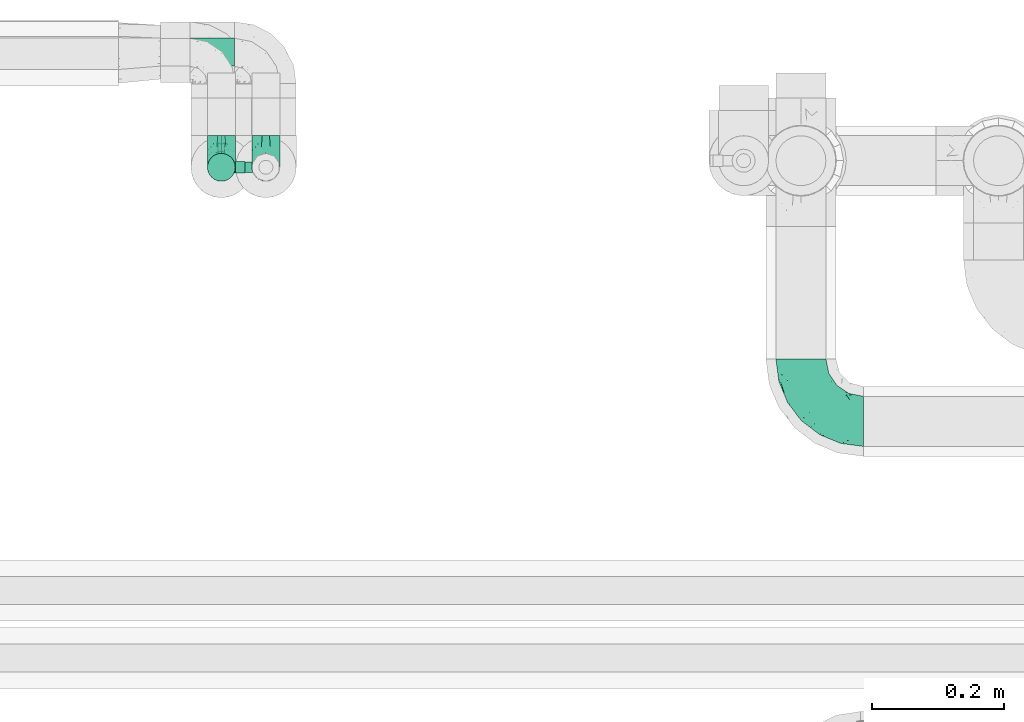
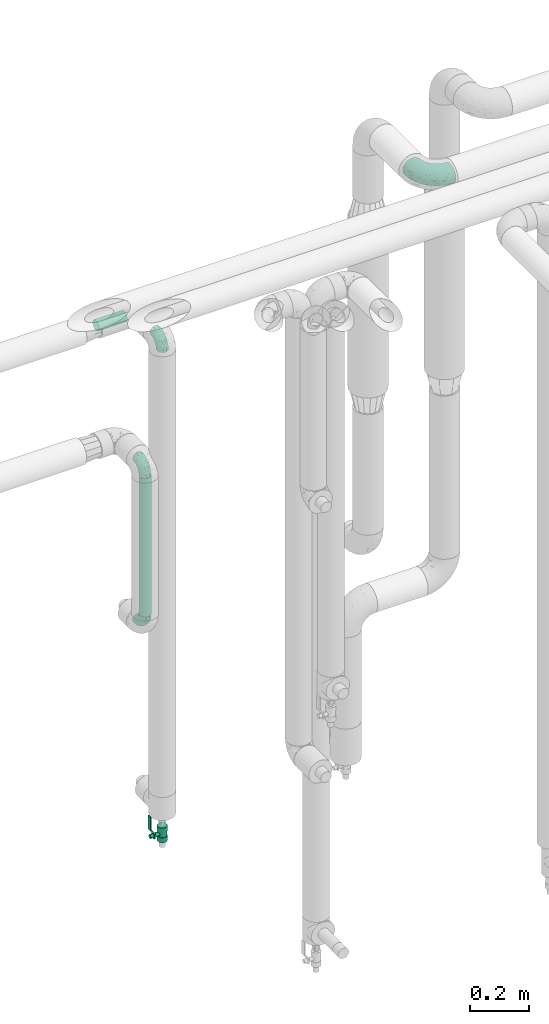
# One storey, part 640 of 827: 4 flow fittings, 2 flow segments, 1 flow controller.
"""IFC2X3 building model written with IfcOpenShell, lengths in millimetres."""

from ifc_helpers import new_model, entity, si_unit, converted_unit, derived_unit, direction, frame, origin, origin_2d_with_axis, place, context, subcontext, project, spatial, polyline, circle, outline, extrude, faceted_brep, source, transform, mapped, material, material_list, type_object, type_shapes, element, save


model = new_model("IFC2X3")

# Units and contexts
model_context = context("Model", 3, precision=0.01, world=origin(), true_north=direction((6.12303176911189e-17, 1.0)))
body_context = subcontext(model_context, "Body", "Model", "MODEL_VIEW")
ifc_project = project(units=[si_unit("LENGTHUNIT", "METRE", prefix="MILLI"), si_unit("AREAUNIT", "SQUARE_METRE"), si_unit("VOLUMEUNIT", "CUBIC_METRE"), converted_unit("PLANEANGLEUNIT", "DEGREE", entity("IfcRatioMeasure", 0.0174532925199433), si_unit("PLANEANGLEUNIT", "RADIAN"), dimensions=[0, 0, 0, 0, 0, 0, 0]), si_unit("MASSUNIT", "GRAM", prefix="KILO"), derived_unit("MASSDENSITYUNIT", [(si_unit("MASSUNIT", "GRAM", prefix="KILO"), 1), (si_unit("LENGTHUNIT", "METRE"), -3)]), derived_unit("MOMENTOFINERTIAUNIT", [(si_unit("LENGTHUNIT", "METRE"), 4)]), si_unit("TIMEUNIT", "SECOND"), si_unit("FREQUENCYUNIT", "HERTZ"), si_unit("THERMODYNAMICTEMPERATUREUNIT", "DEGREE_CELSIUS"), derived_unit("THERMALTRANSMITTANCEUNIT", [(si_unit("MASSUNIT", "GRAM", prefix="KILO"), 1), (si_unit("THERMODYNAMICTEMPERATUREUNIT", "KELVIN"), -1), (si_unit("TIMEUNIT", "SECOND"), -3)]), derived_unit("VOLUMETRICFLOWRATEUNIT", [(si_unit("LENGTHUNIT", "METRE"), 3), (si_unit("TIMEUNIT", "SECOND"), -1)]), derived_unit("MASSFLOWRATEUNIT", [(si_unit("MASSUNIT", "GRAM", prefix="KILO"), 1), (si_unit("TIMEUNIT", "SECOND"), -1)]), derived_unit("ROTATIONALFREQUENCYUNIT", [(si_unit("TIMEUNIT", "SECOND"), -1)]), si_unit("ELECTRICCURRENTUNIT", "AMPERE"), si_unit("ELECTRICVOLTAGEUNIT", "VOLT"), si_unit("POWERUNIT", "WATT"), si_unit("FORCEUNIT", "NEWTON", prefix="KILO"), si_unit("ILLUMINANCEUNIT", "LUX"), si_unit("LUMINOUSFLUXUNIT", "LUMEN"), si_unit("LUMINOUSINTENSITYUNIT", "CANDELA"), derived_unit("USERDEFINED", [(si_unit("MASSUNIT", "GRAM", prefix="KILO"), -1), (si_unit("LENGTHUNIT", "METRE"), -2), (si_unit("TIMEUNIT", "SECOND"), 3), (si_unit("LUMINOUSFLUXUNIT", "LUMEN"), 1)]), derived_unit("LINEARVELOCITYUNIT", [(si_unit("LENGTHUNIT", "METRE"), 1), (si_unit("TIMEUNIT", "SECOND"), -1)]), si_unit("PRESSUREUNIT", "PASCAL"), derived_unit("USERDEFINED", [(si_unit("LENGTHUNIT", "METRE"), -2), (si_unit("MASSUNIT", "GRAM", prefix="KILO"), 1), (si_unit("TIMEUNIT", "SECOND"), -2)]), derived_unit("LINEARFORCEUNIT", [(si_unit("MASSUNIT", "GRAM", prefix="KILO"), 1), (si_unit("LENGTHUNIT", "METRE"), 1), (si_unit("TIMEUNIT", "SECOND"), -2), (si_unit("LENGTHUNIT", "METRE"), -1)]), derived_unit("PLANARFORCEUNIT", [(si_unit("MASSUNIT", "GRAM", prefix="KILO"), 1), (si_unit("LENGTHUNIT", "METRE"), 1), (si_unit("TIMEUNIT", "SECOND"), -2), (si_unit("LENGTHUNIT", "METRE"), -2)])], contexts=[model_context])

# Site, building, storey
site_placement = place(None, origin())
site = spatial("IfcSite", under=ifc_project, at=site_placement, CompositionType="ELEMENT")
building_placement = place(site_placement, origin())
building = spatial("IfcBuilding", under=site, at=building_placement, CompositionType="ELEMENT")
storey_placement = place(building_placement, frame((0.0, 0.0, 28200.0)))
storey = spatial("IfcBuildingStorey", under=building, at=storey_placement, Name="08", CompositionType="ELEMENT", Elevation=28200.0)

# Flow segments
pipe_segment_type = type_object("IfcPipeSegmentType", PredefinedType="NOTDEFINED")
flow_segment_1_placement = place(storey_placement, frame((30551.84, 19320.69, 1178.45)))
element("IfcFlowSegment", 1, at=flow_segment_1_placement, inside=storey, type_object=pipe_segment_type, context=body_context, shape_type="SweptSolid", body=[
    extrude(circle(Radius=21.15, at=origin_2d_with_axis()), frame((22.75, 22.75, 0.0), z_axis=(0.0, 0.0, 1.0), x_axis=(-1.0, 0.0, 0.0)), (0.0, 0.0, 1.0), 573.551740000017),
])
flow_segment_2_placement = place(storey_placement, frame((30482.2, 19495.69, 2277.25)))
element("IfcFlowSegment", 2, at=flow_segment_2_placement, inside=storey, type_object=pipe_segment_type, context=body_context, shape_type="SweptSolid", body=[
    extrude(circle(Radius=21.15, at=origin_2d_with_axis()), frame((0.0, 22.75, 22.75), z_axis=(1.0, 0.0, 0.0), x_axis=(0.0, 1.0, 0.0)), (0.0, 0.0, 1.0), 112.000000000009),
])

# Flow controller
ifc_material = material()
ifc_material_list = material_list([ifc_material, ifc_material, ifc_material, ifc_material, ifc_material])
valve_type = type_object("IfcValveType", PredefinedType="NOTDEFINED", material=ifc_material_list)
shared_shape_1 = source(origin(), body_context, "Body", "SweptSolid", [
    extrude(circle(Radius=17.5, at=origin_2d_with_axis()), frame((-30.5, 0.0, 0.0), z_axis=(1.0, 0.0, 0.0), x_axis=(0.0, 1.0, 0.0)), (0.0, 0.0, 1.0), 20.3333333333333),
    extrude(circle(Radius=16.0, at=origin_2d_with_axis()), frame((-10.17, 0.0, 0.0), z_axis=(1.0, 0.0, 0.0), x_axis=(0.0, 1.0, 0.0)), (0.0, 0.0, 1.0), 20.3333333333333),
    extrude(circle(Radius=17.5, at=origin_2d_with_axis()), frame((10.17, 0.0, 0.0), z_axis=(1.0, 0.0, 0.0), x_axis=(0.0, 1.0, 0.0)), (0.0, 0.0, 1.0), 20.3333333333333),
    extrude(outline(polyline([(-38.75, -5.0), (-38.75, -10.0), (-17.92, -10.0), (2.08, 5.0), (56.25, 5.0), (56.25, 10.0), (0.42, 10.0), (-19.58, -5.0), (-38.75, -5.0)])), frame((28.75, -8.75, 41.5), z_axis=(0.0, -1.0, 0.0), x_axis=(1.0, 0.0, 0.0)), (0.0, 0.0, -1.0), 17.5),
    extrude(circle(Radius=8.0, at=origin_2d_with_axis()), origin(), (0.0, 0.0, 1.0), 49.0),
])
type_shapes(valve_type, [shared_shape_1])
flow_controller_placement = place(storey_placement, frame((30642.2, 19343.43, 245.5), z_axis=(-1.0, 0.0, 0.0), x_axis=(0.0, 0.0, 1.0)))
element("IfcFlowController", 3, at=flow_controller_placement, inside=storey, type_object=valve_type, material=ifc_material, context=body_context, shape_type="MappedRepresentation", body=[
    mapped(shared_shape_1, transform((0.0, 0.0, 0.0), scale=1.0)),
])

# Flow fittings
pipe_fitting_type_1 = type_object("IfcPipeFittingType", Name="ADSK_1", PredefinedType="NOTDEFINED", material=ifc_material)
shared_shape_2 = source(origin(), body_context, "Body", "Brep", [
    faceted_brep([(-48.0, 10.6, -18.36), (-48.0, 5.49, -20.48), (-48.0, 0.0, -21.2), (-48.0, -5.49, -20.48), (-48.0, -10.6, -18.36), (-48.0, -14.99, -14.99), (-48.0, -18.36, -10.6), (-48.0, -20.48, -5.49), (-48.0, -21.2, 0.0), (-48.0, -20.48, 5.49), (-48.0, -18.36, 10.6), (-48.0, -14.99, 14.99), (-48.0, -10.6, 18.36), (-48.0, -5.49, 20.48), (-48.0, 0.0, 21.2), (-48.0, 5.49, 20.48), (-48.0, 10.6, 18.36), (-48.0, 14.99, 14.99), (-48.0, 18.36, 10.6), (-48.0, 20.48, 5.49), (-48.0, 21.2, 0.0), (-48.0, 20.48, -5.49), (-48.0, 18.36, -10.6), (-48.0, 14.99, -14.99), (0.0, 48.0, -21.2), (-5.49, 48.0, -20.48), (-10.6, 48.0, -18.36), (-14.99, 48.0, -14.99), (-18.36, 48.0, -10.6), (-20.48, 48.0, -5.49), (-21.2, 48.0, 0.0), (-20.48, 48.0, 5.49), (-18.36, 48.0, 10.6), (-14.99, 48.0, 14.99), (-10.6, 48.0, 18.36), (-5.49, 48.0, 20.48), (0.0, 48.0, 21.2), (5.49, 48.0, 20.48), (10.6, 48.0, 18.36), (14.99, 48.0, 14.99), (18.36, 48.0, 10.6), (20.48, 48.0, 5.49), (21.2, 48.0, 0.0), (20.48, 48.0, -5.49), (18.36, 48.0, -10.6), (14.99, 48.0, -14.99), (10.6, 48.0, -18.36), (5.49, 48.0, -20.48), (-35.25, -16.22, 12.01), (-34.76, -18.57, 0.0), (-20.87, -12.37, 10.9), (-31.49, -11.78, 15.9), (-37.0, -2.58, 20.86), (-33.89, 3.62, 21.15), (-31.81, -18.14, 6.76), (-5.78, 5.78, 17.67), (-19.42, -4.1, 17.86), (-9.6, -3.39, 13.73), (-35.44, -7.73, 19.13), (11.78, 31.49, 15.9), (-5.93, -5.46, 6.95), (-18.45, -13.78, 5.46), (-10.29, -8.43, 0.0), (-24.6, 0.55, 20.62), (-37.28, 17.94, 13.81), (-33.38, 22.85, 9.59), (-41.46, 20.06, 8.75), (-29.51, 20.45, 15.16), (-15.04, 10.79, 21.13), (-7.08, 16.98, 20.93), (-8.39, 23.51, 21.15), (-40.86, 13.03, 17.26), (-8.05, 41.26, 19.83), (-3.21, 35.97, 21.14), (8.53, 19.66, 14.74), (4.1, 19.42, 17.86), (-37.72, 22.66, 4.78), (-37.07, 8.58, 19.98), (-13.0, 5.43, 19.97), (-3.78, 13.93, 19.7), (3.02, 8.69, 13.43), (-2.27, -0.05, 10.65), (6.22, 6.99, 7.09), (-22.25, 34.6, 9.45), (18.14, 31.81, 6.76), (16.22, 35.25, 12.01), (12.37, 20.87, 10.9), (7.73, 35.44, 19.13), (-21.52, -15.93, 0.0), (2.58, 37.0, 20.86), (18.57, 34.76, 0.0), (13.78, 18.45, 5.46), (15.93, 21.52, 0.0), (-20.03, -8.54, 14.9), (-28.6, 28.6, 5.16), (-24.79, 34.6, 0.0), (-34.6, 24.79, 0.0), (-22.81, 37.41, 4.68), (-23.36, 26.33, 14.79), (-13.68, 37.05, 17.49), (-17.72, 38.12, 13.73), (-26.25, 27.3, 11.24), (-9.71, 32.34, 20.14), (-17.26, 25.6, 18.71), (-26.33, 9.99, 20.77), (-24.06, 6.05, 21.2), (-25.02, 15.46, 19.56), (-24.3, 20.72, 17.57), (-31.95, 15.23, 17.8), (-13.53, 24.7, 20.21), (-17.6, 17.6, 20.6), (-0.55, 24.6, 20.62), (-11.41, -7.48, 10.43), (0.93, -0.93, 0.0), (8.43, 10.29, 0.0), (-11.41, -7.48, -10.43), (-20.1, -8.84, -14.66), (-9.6, -3.39, -13.73), (7.73, 35.44, -19.13), (4.1, 19.42, -17.86), (-0.55, 24.6, -20.62), (-38.12, 17.72, -13.73), (-37.05, 13.68, -17.49), (-32.34, 9.71, -20.14), (-41.26, 8.05, -19.83), (-37.41, 22.81, -4.68), (-23.51, 8.39, -21.15), (-35.97, 3.21, -21.14), (-28.6, 28.6, -5.16), (-31.81, -18.14, -6.76), (-18.45, -13.78, -5.46), (-25.6, 17.26, -18.71), (-19.42, -4.1, -17.86), (-17.94, 37.28, -13.81), (-22.85, 33.38, -9.59), (-20.06, 41.46, -8.75), (-31.49, -11.78, -15.9), (-35.25, -16.22, -12.01), (8.53, 19.66, -14.74), (11.78, 31.49, -15.9), (-9.99, 26.33, -20.77), (-6.05, 24.06, -21.2), (-10.79, 15.04, -21.13), (-37.0, -2.58, -20.86), (-16.98, 7.08, -20.93), (-5.43, 13.0, -19.97), (-13.93, 3.78, -19.7), (-20.87, -12.37, -10.9), (-26.33, 23.36, -14.79), (-22.66, 37.72, -4.78), (13.78, 18.45, -5.46), (18.14, 31.81, -6.76), (-15.46, 25.02, -19.56), (-20.72, 24.3, -17.57), (16.22, 35.25, -12.01), (-13.03, 40.86, -17.26), (-8.58, 37.07, -19.98), (2.58, 37.0, -20.86), (-3.62, 33.89, -21.15), (-34.6, 22.25, -9.45), (6.22, 6.99, -7.09), (-20.45, 29.51, -15.16), (-35.44, -7.73, -19.13), (12.37, 20.87, -10.9), (-27.3, 26.25, -11.24), (-15.23, 31.95, -17.8), (-24.7, 13.53, -20.21), (-24.6, 0.55, -20.62), (-5.78, 5.78, -17.67), (-17.6, 17.6, -20.6), (3.02, 8.69, -13.43), (-5.93, -5.46, -6.95), (-2.27, -0.05, -10.65)], [[[0, 1, 2, 3, 4, 5, 6, 7, 8, 9, 10, 11, 12, 13, 14, 15, 16, 17, 18, 19, 20, 21, 22, 23]], [[24, 25, 26, 27, 28, 29, 30, 31, 32, 33, 34, 35, 36, 37, 38, 39, 40, 41, 42, 43, 44, 45, 46, 47]], [[10, 48, 11]], [[9, 8, 49]], [[48, 50, 51]], [[14, 52, 53]], [[10, 54, 48]], [[9, 54, 10]], [[55, 56, 57]], [[51, 12, 11]], [[51, 58, 12]], [[59, 39, 38]], [[60, 61, 62]], [[58, 56, 63]], [[64, 65, 66]], [[67, 65, 64]], [[68, 69, 70]], [[16, 71, 17]], [[13, 52, 14]], [[35, 72, 73]], [[14, 53, 15]], [[17, 64, 18]], [[74, 59, 75]], [[20, 19, 76]], [[66, 19, 18]], [[77, 15, 53]], [[15, 77, 16]], [[69, 78, 79]], [[80, 81, 82]], [[32, 31, 83]], [[84, 85, 86]], [[59, 87, 75]], [[61, 54, 88]], [[36, 89, 37]], [[84, 41, 40]], [[36, 35, 73]], [[90, 41, 84]], [[40, 39, 85]], [[12, 58, 13]], [[85, 84, 40]], [[91, 84, 86]], [[84, 92, 90]], [[87, 38, 37]], [[93, 56, 51]], [[65, 94, 76]], [[94, 95, 96]], [[84, 91, 92]], [[95, 97, 30]], [[98, 99, 100]], [[76, 94, 96]], [[101, 98, 83]], [[100, 99, 33]], [[102, 70, 73]], [[103, 102, 99]], [[94, 97, 95]], [[72, 99, 102]], [[72, 35, 34]], [[34, 33, 99]], [[9, 49, 54]], [[87, 59, 38]], [[104, 105, 68]], [[106, 103, 107]], [[106, 77, 104]], [[71, 64, 17]], [[108, 107, 67]], [[33, 32, 100]], [[109, 103, 110]], [[102, 109, 70]], [[89, 73, 111]], [[50, 48, 54]], [[51, 11, 48]], [[56, 58, 51]], [[88, 54, 49]], [[52, 58, 63]], [[50, 112, 93]], [[56, 55, 78]], [[39, 59, 85]], [[86, 85, 59]], [[89, 87, 37]], [[42, 41, 90]], [[111, 79, 75]], [[111, 75, 87]], [[75, 55, 80]], [[104, 77, 53]], [[71, 77, 108]], [[32, 83, 100]], [[98, 100, 83]], [[99, 98, 103]], [[106, 107, 108]], [[68, 70, 110]], [[111, 73, 70]], [[68, 110, 104]], [[68, 63, 78]], [[57, 93, 112]], [[80, 55, 57]], [[61, 50, 54]], [[80, 82, 86]], [[81, 57, 112]], [[74, 86, 59]], [[60, 113, 82]], [[82, 114, 91]], [[101, 94, 65]], [[97, 94, 83]], [[73, 89, 36]], [[87, 89, 111]], [[58, 52, 13]], [[53, 52, 63]], [[104, 53, 105]], [[106, 104, 110]], [[20, 76, 96]], [[76, 19, 66]], [[103, 106, 110]], [[77, 106, 108]], [[103, 98, 107]], [[67, 107, 98]], [[67, 98, 101]], [[108, 67, 64]], [[53, 63, 105]], [[63, 68, 105]], [[83, 31, 97]], [[30, 97, 31]], [[62, 113, 60]], [[112, 61, 60]], [[61, 88, 62]], [[86, 82, 91]], [[56, 78, 63]], [[114, 82, 113]], [[114, 92, 91]], [[79, 78, 55]], [[75, 79, 55]], [[69, 79, 111]], [[70, 69, 111]], [[78, 69, 68]], [[77, 71, 16]], [[64, 71, 108]], [[64, 66, 18]], [[76, 66, 65]], [[99, 72, 34]], [[73, 72, 102]], [[94, 101, 83]], [[67, 101, 65]], [[75, 80, 74]], [[80, 86, 74]], [[70, 109, 110]], [[102, 103, 109]], [[50, 93, 51]], [[57, 56, 93]], [[61, 112, 50]], [[81, 112, 60]], [[82, 81, 60]], [[80, 57, 81]], [[115, 116, 117]], [[118, 119, 120]], [[121, 122, 23]], [[123, 124, 122]], [[96, 125, 20]], [[123, 126, 127]], [[128, 96, 95]], [[129, 130, 88]], [[123, 122, 131]], [[116, 132, 117]], [[133, 134, 135]], [[0, 124, 1]], [[5, 136, 137]], [[138, 119, 139]], [[129, 88, 49]], [[140, 141, 142]], [[6, 5, 137]], [[46, 118, 47]], [[143, 3, 2]], [[144, 145, 146]], [[6, 129, 7]], [[129, 137, 147]], [[127, 2, 1]], [[148, 122, 121]], [[128, 125, 96]], [[134, 128, 149]], [[95, 149, 128]], [[150, 151, 92]], [[30, 29, 149]], [[152, 131, 153]], [[27, 133, 28]], [[154, 45, 44]], [[136, 5, 4]], [[27, 26, 155]], [[156, 26, 25]], [[24, 157, 158]], [[24, 47, 157]], [[22, 21, 159]], [[160, 150, 114]], [[134, 133, 161]], [[142, 144, 126]], [[46, 139, 118]], [[162, 136, 4]], [[156, 25, 158]], [[1, 124, 127]], [[115, 147, 116]], [[45, 154, 139]], [[139, 46, 45]], [[154, 163, 139]], [[162, 4, 3]], [[42, 90, 43]], [[130, 129, 147]], [[49, 7, 129]], [[43, 151, 44]], [[0, 23, 122]], [[24, 158, 25]], [[136, 162, 132]], [[135, 29, 28]], [[43, 90, 151]], [[164, 148, 159]], [[152, 156, 140]], [[155, 133, 27]], [[165, 153, 161]], [[23, 22, 121]], [[123, 131, 166]], [[123, 166, 126]], [[143, 127, 167]], [[147, 137, 136]], [[8, 7, 49]], [[129, 6, 137]], [[143, 162, 3]], [[167, 146, 132]], [[167, 132, 162]], [[132, 168, 117]], [[44, 151, 154]], [[92, 151, 90]], [[163, 154, 151]], [[119, 118, 139]], [[157, 118, 120]], [[138, 139, 163]], [[119, 168, 145]], [[140, 156, 158]], [[155, 156, 165]], [[22, 159, 121]], [[148, 121, 159]], [[122, 148, 131]], [[152, 153, 165]], [[142, 126, 169]], [[167, 127, 126]], [[142, 169, 140]], [[142, 120, 145]], [[168, 170, 117]], [[160, 171, 172]], [[115, 172, 171]], [[171, 62, 130]], [[119, 170, 168]], [[170, 163, 160]], [[150, 163, 151]], [[113, 171, 160]], [[164, 128, 134]], [[125, 128, 159]], [[127, 143, 2]], [[162, 143, 167]], [[118, 157, 47]], [[158, 157, 120]], [[140, 158, 141]], [[152, 140, 169]], [[30, 149, 95]], [[149, 29, 135]], [[131, 152, 169]], [[156, 152, 165]], [[131, 148, 153]], [[161, 153, 148]], [[161, 148, 164]], [[165, 161, 133]], [[158, 120, 141]], [[120, 142, 141]], [[159, 21, 125]], [[20, 125, 21]], [[115, 130, 147]], [[114, 113, 160]], [[62, 171, 113]], [[62, 88, 130]], [[160, 163, 150]], [[150, 92, 114]], [[119, 145, 120]], [[146, 145, 168]], [[132, 146, 168]], [[144, 146, 167]], [[126, 144, 167]], [[145, 144, 142]], [[156, 155, 26]], [[133, 155, 165]], [[133, 135, 28]], [[149, 135, 134]], [[122, 124, 0]], [[127, 124, 123]], [[128, 164, 159]], [[161, 164, 134]], [[163, 170, 138]], [[170, 119, 138]], [[131, 169, 166]], [[126, 166, 169]], [[147, 136, 116]], [[132, 116, 136]], [[172, 115, 117]], [[130, 115, 171]], [[117, 170, 172]], [[160, 172, 170]]]),
])
type_shapes(pipe_fitting_type_1, [shared_shape_2])
for number, where, z_axis, x_axis, name in (
    (4, (30642.2, 19343.43, 2300.0), (1.0, 0.0, 0.0), (0.0, -1.0, 0.0), "ADSK_1"),
    (5, (30574.59, 19343.43, 1800.0), (1.0, 0.0, 0.0), (0.0, -1.0, 0.0), "ADSK_1"),
    (6, (30574.59, 19343.43, 1130.45), (1.0, 0.0, 0.0), (0.0, 0.0, -1.0), "ADSK_1"),
):
    element("IfcFlowFitting", number, at=place(storey_placement, frame(where, z_axis=z_axis, x_axis=x_axis)), inside=storey, type_object=pipe_fitting_type_1, material=ifc_material, Name=name, ObjectType="ADSK_1", context=body_context, shape_type="MappedRepresentation", body=[
        mapped(shared_shape_2, transform((0.0, 0.0, 0.0), scale=1.0)),
    ])
pipe_fitting_type_2 = type_object("IfcPipeFittingType", Name="ADSK_1", PredefinedType="NOTDEFINED", material=ifc_material)
shared_shape_3 = source(origin(), body_context, "Body", "Brep", [
    faceted_brep([(-95.0, 19.02, -32.95), (-95.0, 9.85, -36.75), (-95.0, 0.0, -38.05), (-95.0, -9.85, -36.75), (-95.0, -19.03, -32.95), (-95.0, -26.91, -26.91), (-95.0, -32.95, -19.03), (-95.0, -36.75, -9.85), (-95.0, -38.05, 0.0), (-95.0, -36.75, 9.85), (-95.0, -32.95, 19.02), (-95.0, -26.91, 26.91), (-95.0, -19.03, 32.95), (-95.0, -9.85, 36.75), (-95.0, 0.0, 38.05), (-95.0, 9.85, 36.75), (-95.0, 19.02, 32.95), (-95.0, 26.91, 26.91), (-95.0, 32.95, 19.02), (-95.0, 36.75, 9.85), (-95.0, 38.05, 0.0), (-95.0, 36.75, -9.85), (-95.0, 32.95, -19.03), (-95.0, 26.91, -26.91), (0.0, 95.0, -38.05), (-9.85, 95.0, -36.75), (-19.02, 95.0, -32.95), (-26.91, 95.0, -26.91), (-32.95, 95.0, -19.03), (-36.75, 95.0, -9.85), (-38.05, 95.0, 0.0), (-36.75, 95.0, 9.85), (-32.95, 95.0, 19.02), (-26.91, 95.0, 26.91), (-19.02, 95.0, 32.95), (-9.85, 95.0, 36.75), (0.0, 95.0, 38.05), (9.85, 95.0, 36.75), (19.03, 95.0, 32.95), (26.91, 95.0, 26.91), (32.95, 95.0, 19.02), (36.75, 95.0, 9.85), (38.05, 95.0, 0.0), (36.75, 95.0, -9.85), (32.95, 95.0, -19.03), (26.91, 95.0, -26.91), (19.03, 95.0, -32.95), (9.85, 95.0, -36.75), (-7.99, -4.96, 6.3), (-0.92, 0.92, 0.0), (4.62, 8.1, 8.01), (-76.19, -35.57, 0.0), (-64.32, -32.32, 12.43), (20.51, 62.45, 28.68), (-60.56, -33.52, 0.0), (-70.4, -13.47, 34.42), (-39.61, -5.88, 32.32), (-49.6, 2.07, 37.1), (-70.34, -28.81, 21.71), (14.64, 40.81, 26.5), (5.88, 39.61, 32.32), (3.59, 20.77, 25.31), (-40.45, 68.06, 16.75), (-62.45, -20.51, 28.68), (-44.52, -26.87, 0.0), (-28.47, -20.22, 0.0), (-26.43, -17.83, 8.75), (-76.1, 39.63, 10.76), (-72.74, 37.58, 18.19), (-60.35, 46.18, 14.61), (-13.4, 13.4, 32.12), (-20.77, -3.59, 25.31), (-14.66, 81.47, 35.56), (-6.22, 71.26, 37.92), (-57.5, 42.48, 22.79), (-15.0, 34.74, 37.7), (-27.1, 12.08, 36.05), (-9.2, 28.81, 35.63), (-79.98, 23.7, 30.95), (-73.68, -4.3, 37.48), (-30.74, 21.67, 37.97), (-62.36, 47.59, 6.79), (-72.71, 32.83, 24.69), (-67.42, 7.02, 37.95), (-32.13, 75.27, 24.51), (-43.46, 51.47, 26.26), (-24.98, 73.15, 31.29), (20.59, 41.28, 19.85), (7.79, 16.09, 15.86), (-73.21, 42.39, 0.0), (-54.73, 54.73, 0.0), (-73.44, 15.79, 35.79), (-5.94, 4.32, 20.43), (28.81, 70.34, 21.71), (32.32, 64.32, 12.43), (-53.59, 26.2, 35.09), (-52.02, 19.31, 37.21), (21.38, 33.53, 10.34), (26.87, 44.52, 0.0), (-48.28, 12.14, 38.05), (4.3, 73.68, 37.48), (-44.08, -25.52, 12.79), (-41.28, -20.59, 19.85), (35.57, 76.19, 0.0), (-47.26, 54.3, 20.18), (-47.4, 61.99, 8.58), (-42.39, 73.21, 0.0), (-39.67, 78.86, 7.21), (-45.69, 36.84, 33.11), (-32.83, 50.13, 33.35), (13.47, 70.4, 34.42), (-18.25, 63.73, 36.07), (-40.63, -13.75, 27.22), (-16.63, 46.37, 37.95), (-53.47, 38.79, 28.59), (-26.07, 48.54, 36.15), (-34.51, 34.51, 36.86), (-2.07, 49.6, 37.1), (-22.79, -10.49, 19.23), (-61.73, 28.67, 31.87), (9.65, 14.7, 0.0), (20.22, 28.47, 0.0), (33.52, 60.56, 0.0), (-11.42, -5.44, 13.25), (-14.7, -9.65, 0.0), (-81.47, 14.66, -35.56), (-62.45, -20.51, -28.68), (-71.26, 6.22, -37.92), (-75.27, 32.13, -24.51), (-73.15, 24.98, -31.29), (13.47, 70.4, -34.42), (5.88, 39.61, -32.32), (-2.07, 49.6, -37.1), (-78.86, 39.67, -7.21), (-70.4, -13.47, -34.42), (-39.61, -5.88, -32.32), (-61.99, 47.4, -8.58), (32.32, 64.32, -12.43), (28.81, 70.34, -21.71), (-63.73, 18.25, -36.07), (-50.13, 32.83, -33.35), (4.3, 73.68, -37.48), (-7.02, 67.42, -37.95), (-39.63, 76.1, -10.76), (-46.18, 60.35, -14.61), (-47.59, 62.36, -6.79), (-64.32, -32.32, -12.43), (-26.2, 53.59, -35.09), (-15.79, 73.44, -35.79), (-19.31, 52.02, -37.21), (-37.58, 72.74, -18.19), (-70.34, -28.81, -21.71), (-42.48, 57.5, -22.79), (-38.79, 53.47, -28.59), (-51.47, 43.46, -26.26), (-32.83, 72.71, -24.69), (-46.37, 16.63, -37.95), (-73.68, -4.3, -37.48), (-41.28, -20.59, -19.85), (-44.08, -25.52, -12.79), (13.75, 40.63, -27.22), (20.51, 62.45, -28.68), (-68.06, 40.45, -16.75), (-54.3, 47.26, -20.18), (-12.14, 48.28, -38.05), (-21.67, 30.74, -37.97), (-36.84, 45.69, -33.11), (-11.42, -5.44, -13.25), (7.79, 16.09, -15.86), (4.62, 8.1, -8.01), (-23.7, 79.98, -30.95), (-26.43, -17.83, -8.75), (-7.99, -4.96, -6.3), (-40.81, -14.64, -26.5), (-20.77, -3.59, -25.31), (-34.74, 15.0, -37.7), (-12.08, 27.1, -36.05), (-28.81, 9.2, -35.63), (-22.79, -10.49, -19.23), (21.38, 33.53, -10.34), (20.59, 41.28, -19.85), (-48.54, 26.07, -36.15), (-49.6, 2.07, -37.1), (-13.4, 13.4, -32.12), (3.59, 20.77, -25.31), (-28.67, 61.73, -31.87), (-34.51, 34.51, -36.86), (-5.94, 4.32, -20.43)], [[[0, 1, 2, 3, 4, 5, 6, 7, 8, 9, 10, 11, 12, 13, 14, 15, 16, 17, 18, 19, 20, 21, 22, 23]], [[24, 25, 26, 27, 28, 29, 30, 31, 32, 33, 34, 35, 36, 37, 38, 39, 40, 41, 42, 43, 44, 45, 46, 47]], [[48, 49, 50]], [[51, 52, 9]], [[53, 39, 38]], [[9, 52, 10]], [[54, 52, 51]], [[55, 56, 57]], [[11, 10, 58]], [[59, 60, 61]], [[32, 31, 62]], [[63, 12, 11]], [[63, 55, 12]], [[64, 65, 66]], [[67, 68, 69]], [[70, 56, 71]], [[35, 72, 73]], [[69, 68, 74]], [[75, 76, 77]], [[16, 78, 17]], [[13, 79, 14]], [[76, 75, 80]], [[67, 69, 81]], [[18, 17, 82]], [[14, 79, 83]], [[20, 19, 67]], [[84, 85, 86]], [[87, 61, 88]], [[89, 81, 90]], [[18, 82, 68]], [[15, 91, 16]], [[14, 83, 15]], [[71, 92, 61]], [[17, 78, 82]], [[93, 87, 94]], [[95, 91, 96]], [[97, 98, 94]], [[86, 72, 34]], [[96, 99, 80]], [[37, 36, 100]], [[40, 39, 93]], [[40, 94, 41]], [[64, 66, 101]], [[93, 94, 40]], [[58, 102, 63]], [[94, 103, 41]], [[94, 87, 97]], [[104, 69, 74]], [[34, 33, 86]], [[105, 69, 104]], [[52, 58, 10]], [[106, 107, 30]], [[108, 109, 85]], [[105, 106, 90]], [[53, 110, 60]], [[86, 111, 72]], [[86, 109, 111]], [[33, 84, 86]], [[12, 55, 13]], [[112, 56, 63]], [[110, 38, 37]], [[34, 72, 35]], [[36, 35, 73]], [[111, 113, 73]], [[105, 107, 106]], [[110, 53, 38]], [[74, 114, 85]], [[91, 15, 83]], [[105, 90, 81]], [[107, 62, 31]], [[33, 32, 84]], [[115, 109, 116]], [[111, 115, 113]], [[100, 73, 117]], [[56, 55, 63]], [[79, 55, 57]], [[102, 118, 112]], [[56, 70, 76]], [[100, 110, 37]], [[117, 77, 60]], [[117, 60, 110]], [[60, 70, 61]], [[58, 52, 101]], [[63, 11, 58]], [[39, 53, 93]], [[87, 93, 53]], [[96, 91, 83]], [[78, 91, 119]], [[32, 62, 84]], [[84, 62, 104]], [[86, 85, 109]], [[85, 114, 108]], [[80, 113, 116]], [[117, 73, 113]], [[80, 116, 96]], [[80, 57, 76]], [[71, 112, 118]], [[61, 87, 59]], [[62, 107, 105]], [[97, 120, 121]], [[70, 71, 61]], [[71, 118, 92]], [[73, 100, 36]], [[110, 100, 117]], [[55, 79, 13]], [[83, 79, 57]], [[96, 83, 99]], [[116, 108, 95]], [[50, 97, 88]], [[97, 87, 88]], [[50, 49, 120]], [[122, 94, 98]], [[89, 20, 67]], [[105, 81, 69]], [[89, 67, 81]], [[68, 19, 18]], [[68, 67, 19]], [[74, 68, 82]], [[114, 82, 119]], [[74, 85, 104]], [[82, 114, 74]], [[114, 119, 108]], [[95, 108, 119]], [[116, 109, 108]], [[123, 48, 50]], [[97, 50, 120]], [[123, 50, 88]], [[91, 95, 119]], [[116, 95, 96]], [[84, 104, 85]], [[104, 62, 105]], [[83, 57, 99]], [[57, 80, 99]], [[66, 48, 123]], [[66, 124, 48]], [[118, 66, 123]], [[124, 66, 65]], [[66, 118, 101]], [[54, 64, 52]], [[124, 49, 48]], [[30, 107, 31]], [[91, 78, 16]], [[82, 78, 119]], [[56, 76, 57]], [[77, 76, 70]], [[60, 77, 70]], [[77, 117, 75]], [[117, 113, 75]], [[113, 80, 75]], [[9, 8, 51]], [[103, 94, 122]], [[103, 42, 41]], [[73, 72, 111]], [[113, 115, 116]], [[111, 109, 115]], [[102, 112, 63]], [[71, 56, 112]], [[118, 102, 101]], [[92, 123, 88]], [[123, 92, 118]], [[61, 92, 88]], [[87, 53, 59]], [[60, 59, 53]], [[97, 121, 98]], [[58, 101, 102]], [[64, 101, 52]], [[125, 1, 0]], [[126, 5, 4]], [[2, 1, 127]], [[1, 125, 127]], [[128, 129, 23]], [[130, 131, 132]], [[89, 133, 20]], [[126, 134, 135]], [[136, 89, 90]], [[137, 138, 44]], [[139, 129, 140]], [[24, 141, 142]], [[143, 144, 145]], [[125, 129, 139]], [[6, 146, 7]], [[147, 148, 149]], [[146, 51, 7]], [[143, 150, 144]], [[146, 6, 151]], [[152, 153, 154]], [[126, 4, 134]], [[0, 23, 129]], [[28, 155, 150]], [[43, 42, 103]], [[54, 146, 64]], [[139, 156, 127]], [[157, 3, 2]], [[151, 158, 159]], [[160, 131, 161]], [[22, 21, 162]], [[136, 144, 163]], [[149, 164, 165]], [[24, 142, 25]], [[166, 140, 154]], [[154, 129, 128]], [[143, 30, 29]], [[167, 168, 169]], [[155, 28, 27]], [[26, 170, 27]], [[171, 167, 172]], [[26, 25, 148]], [[27, 170, 155]], [[173, 135, 174]], [[144, 150, 152]], [[175, 176, 177]], [[24, 47, 141]], [[45, 161, 46]], [[148, 25, 142]], [[176, 175, 165]], [[64, 159, 171]], [[138, 45, 44]], [[130, 46, 161]], [[137, 44, 43]], [[178, 159, 158]], [[137, 103, 122]], [[163, 144, 152]], [[136, 133, 89]], [[103, 137, 43]], [[6, 5, 151]], [[178, 158, 173]], [[134, 4, 3]], [[178, 173, 174]], [[137, 98, 179]], [[145, 90, 106]], [[138, 180, 161]], [[46, 130, 47]], [[136, 90, 145]], [[133, 162, 21]], [[23, 22, 128]], [[139, 140, 181]], [[139, 181, 156]], [[157, 127, 182]], [[157, 134, 3]], [[182, 177, 135]], [[182, 135, 134]], [[135, 183, 174]], [[131, 130, 161]], [[141, 130, 132]], [[160, 180, 184]], [[131, 183, 176]], [[5, 126, 151]], [[158, 151, 126]], [[180, 138, 137]], [[161, 45, 138]], [[149, 148, 142]], [[170, 148, 185]], [[22, 162, 128]], [[128, 162, 163]], [[129, 154, 140]], [[154, 153, 166]], [[165, 156, 186]], [[182, 127, 156]], [[165, 186, 149]], [[165, 132, 176]], [[131, 184, 183]], [[187, 167, 178]], [[184, 168, 187]], [[167, 169, 172]], [[184, 180, 168]], [[174, 183, 184]], [[127, 157, 2]], [[134, 157, 182]], [[130, 141, 47]], [[142, 141, 132]], [[149, 142, 164]], [[186, 166, 147]], [[180, 179, 168]], [[169, 179, 120]], [[137, 179, 180]], [[179, 121, 120]], [[106, 30, 143]], [[136, 145, 144]], [[106, 143, 145]], [[150, 29, 28]], [[150, 143, 29]], [[152, 150, 155]], [[153, 155, 185]], [[152, 154, 163]], [[155, 153, 152]], [[153, 185, 166]], [[147, 166, 185]], [[186, 140, 166]], [[169, 120, 49]], [[169, 49, 172]], [[179, 169, 168]], [[148, 147, 185]], [[186, 147, 149]], [[128, 163, 154]], [[163, 162, 136]], [[142, 132, 164]], [[132, 165, 164]], [[171, 124, 65]], [[124, 171, 172]], [[64, 146, 159]], [[171, 159, 178]], [[171, 65, 64]], [[172, 49, 124]], [[162, 133, 136]], [[20, 133, 21]], [[148, 170, 26]], [[155, 170, 185]], [[131, 176, 132]], [[177, 176, 183]], [[135, 177, 183]], [[177, 182, 175]], [[182, 156, 175]], [[156, 165, 175]], [[51, 146, 54]], [[51, 8, 7]], [[129, 125, 0]], [[127, 125, 139]], [[140, 186, 181]], [[156, 181, 186]], [[158, 126, 173]], [[135, 173, 126]], [[187, 178, 174]], [[171, 178, 167]], [[184, 187, 174]], [[167, 187, 168]], [[180, 160, 161]], [[184, 131, 160]], [[98, 137, 122]], [[98, 121, 179]], [[151, 159, 146]]]),
])
type_shapes(pipe_fitting_type_2, [shared_shape_3])
flow_fitting_placement = place(storey_placement, frame((31455.41, 18957.24, 2900.08), z_axis=(0.0, 0.0, 1.0), x_axis=(0.0, -1.0, 0.0)))
element("IfcFlowFitting", 7, at=flow_fitting_placement, inside=storey, type_object=pipe_fitting_type_2, material=ifc_material, Name="ADSK_1", ObjectType="ADSK_1", context=body_context, shape_type="MappedRepresentation", body=[
    mapped(shared_shape_3, transform((0.0, 0.0, 0.0), scale=1.0)),
])

save(model, "model.ifc")
